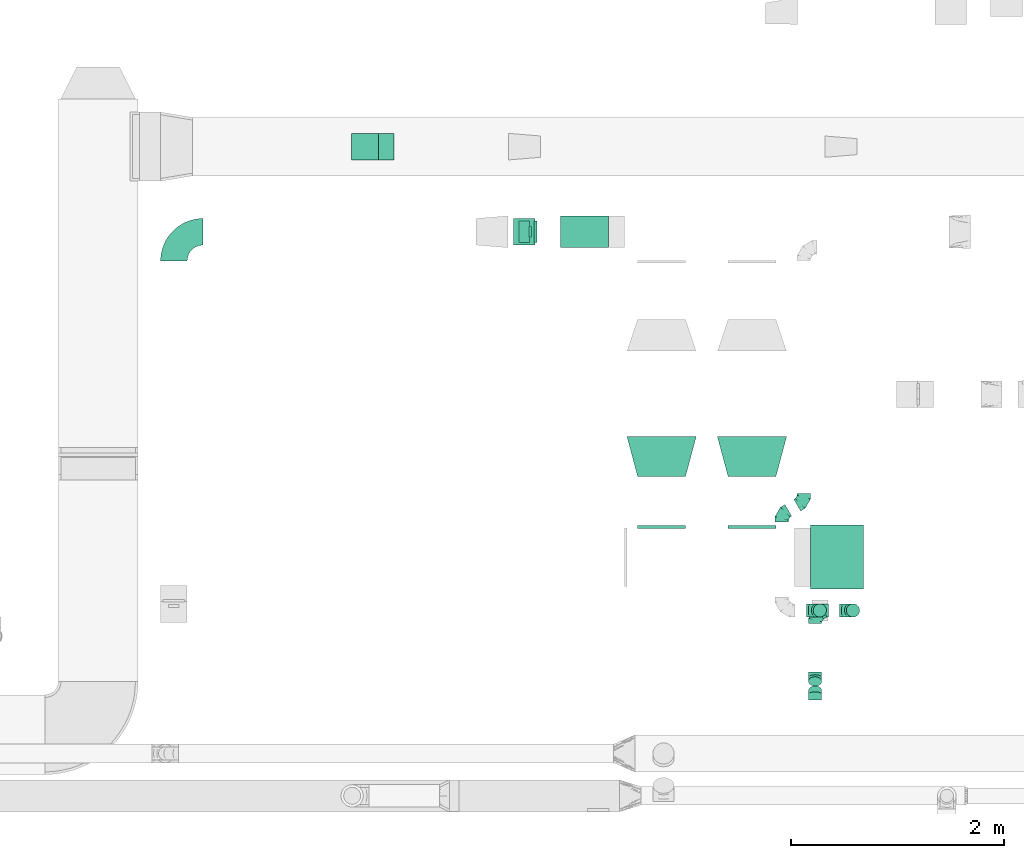
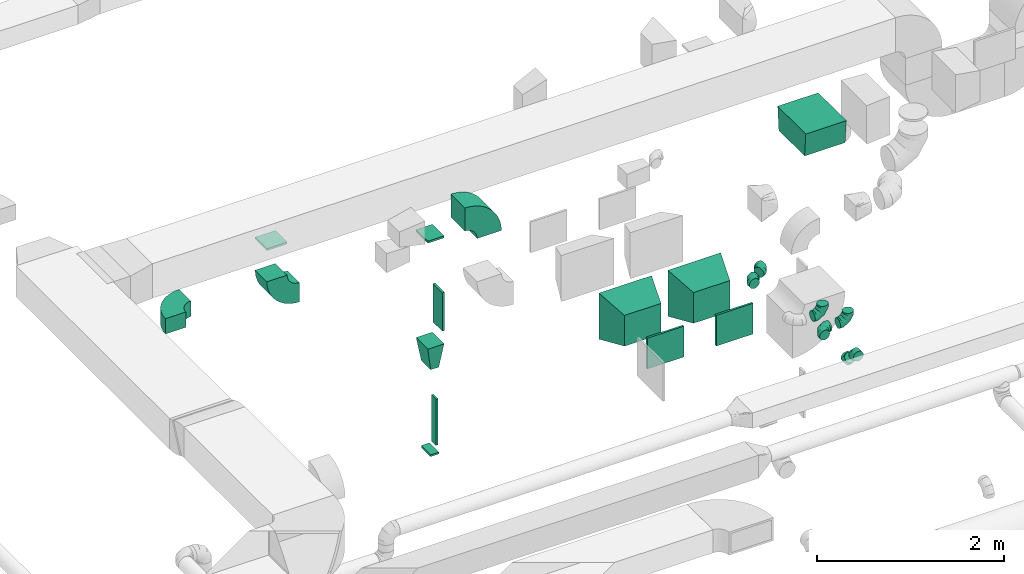
# One storey, part 57 of 97: 21 flow fittings.
"""IFC2X3 building model written with IfcOpenShell, lengths in millimetres."""

from ifc_helpers import new_model, entity, si_unit, converted_unit, derived_unit, direction, frame, frame_2d, origin, origin_2d_with_axis, place, context, subcontext, project, spatial, polyline, circle_curve, parameter, trimmed, segment, composite_curve, rectangle, outline, extrude, faceted_brep, source, transform, mapped, material, type_object, type_shapes, element, save


model = new_model("IFC2X3")

# Units and contexts
model_context = context("Model", 3, precision=0.01, world=origin(), true_north=direction((6.12303176911189e-17, 1.0)))
body_context = subcontext(model_context, "Body", "Model", "MODEL_VIEW")
ifc_project = project(units=[si_unit("LENGTHUNIT", "METRE", prefix="MILLI"), si_unit("AREAUNIT", "SQUARE_METRE"), si_unit("VOLUMEUNIT", "CUBIC_METRE"), converted_unit("PLANEANGLEUNIT", "DEGREE", entity("IfcRatioMeasure", 0.0174532925199433), si_unit("PLANEANGLEUNIT", "RADIAN"), dimensions=[0, 0, 0, 0, 0, 0, 0]), si_unit("MASSUNIT", "GRAM", prefix="KILO"), derived_unit("MASSDENSITYUNIT", [(si_unit("MASSUNIT", "GRAM", prefix="KILO"), 1), (si_unit("LENGTHUNIT", "METRE"), -3)]), derived_unit("MOMENTOFINERTIAUNIT", [(si_unit("LENGTHUNIT", "METRE"), 4)]), si_unit("TIMEUNIT", "SECOND"), si_unit("FREQUENCYUNIT", "HERTZ"), si_unit("THERMODYNAMICTEMPERATUREUNIT", "DEGREE_CELSIUS"), derived_unit("THERMALTRANSMITTANCEUNIT", [(si_unit("MASSUNIT", "GRAM", prefix="KILO"), 1), (si_unit("THERMODYNAMICTEMPERATUREUNIT", "KELVIN"), -1), (si_unit("TIMEUNIT", "SECOND"), -3)]), derived_unit("VOLUMETRICFLOWRATEUNIT", [(si_unit("LENGTHUNIT", "METRE"), 3), (si_unit("TIMEUNIT", "SECOND"), -1)]), derived_unit("MASSFLOWRATEUNIT", [(si_unit("MASSUNIT", "GRAM", prefix="KILO"), 1), (si_unit("TIMEUNIT", "SECOND"), -1)]), derived_unit("ROTATIONALFREQUENCYUNIT", [(si_unit("TIMEUNIT", "SECOND"), -1)]), si_unit("ELECTRICCURRENTUNIT", "AMPERE"), si_unit("ELECTRICVOLTAGEUNIT", "VOLT"), si_unit("POWERUNIT", "WATT"), si_unit("FORCEUNIT", "NEWTON", prefix="KILO"), si_unit("ILLUMINANCEUNIT", "LUX"), si_unit("LUMINOUSFLUXUNIT", "LUMEN"), si_unit("LUMINOUSINTENSITYUNIT", "CANDELA"), derived_unit("USERDEFINED", [(si_unit("MASSUNIT", "GRAM", prefix="KILO"), -1), (si_unit("LENGTHUNIT", "METRE"), -2), (si_unit("TIMEUNIT", "SECOND"), 3), (si_unit("LUMINOUSFLUXUNIT", "LUMEN"), 1)]), derived_unit("LINEARVELOCITYUNIT", [(si_unit("LENGTHUNIT", "METRE"), 1), (si_unit("TIMEUNIT", "SECOND"), -1)]), si_unit("PRESSUREUNIT", "PASCAL"), derived_unit("USERDEFINED", [(si_unit("LENGTHUNIT", "METRE"), -2), (si_unit("MASSUNIT", "GRAM", prefix="KILO"), 1), (si_unit("TIMEUNIT", "SECOND"), -2)]), derived_unit("LINEARFORCEUNIT", [(si_unit("MASSUNIT", "GRAM", prefix="KILO"), 1), (si_unit("LENGTHUNIT", "METRE"), 1), (si_unit("TIMEUNIT", "SECOND"), -2), (si_unit("LENGTHUNIT", "METRE"), -1)]), derived_unit("PLANARFORCEUNIT", [(si_unit("MASSUNIT", "GRAM", prefix="KILO"), 1), (si_unit("LENGTHUNIT", "METRE"), 1), (si_unit("TIMEUNIT", "SECOND"), -2), (si_unit("LENGTHUNIT", "METRE"), -2)])], contexts=[model_context])

# Site, building, storey
site_placement = place(None, origin())
site = spatial("IfcSite", under=ifc_project, at=site_placement, CompositionType="ELEMENT")
building_placement = place(site_placement, origin())
building = spatial("IfcBuilding", under=site, at=building_placement, CompositionType="ELEMENT")
storey_placement = place(building_placement, frame((0.0, 0.0, -4900.0)))
storey = spatial("IfcBuildingStorey", under=building, at=storey_placement, CompositionType="ELEMENT", Elevation=-4900.0)

# Flow fittings
ifc_material = material()
duct_fitting_type_1 = type_object("IfcDuctFittingType", PredefinedType="NOTDEFINED", material=ifc_material)
shared_shape_1 = source(origin(), body_context, "Body", "SweptSolid", [
    extrude(rectangle(XDim=250.0, YDim=26.0960000000487, at=origin_2d_with_axis()), frame((6.95, 0.0, -125.0), z_axis=(0.0, 0.0, 1.0), x_axis=(0.0, -1.0, 0.0)), (0.0, 0.0, 1.0), 250.0),
])
type_shapes(duct_fitting_type_1, [shared_shape_1])
flow_fitting_1_placement = place(storey_placement, frame((40818.26, 15349.1, 4000.0), z_axis=(1.0, 0.0, 0.0), x_axis=(0.0, 0.0, -1.0)))
element("IfcFlowFitting", 1, at=flow_fitting_1_placement, inside=storey, type_object=duct_fitting_type_1, material=ifc_material, context=body_context, shape_type="MappedRepresentation", body=[
    mapped(shared_shape_1, transform((0.0, 0.0, 0.0), scale=1.0)),
])
duct_fitting_type_2 = type_object("IfcDuctFittingType", PredefinedType="NOTDEFINED", material=ifc_material)
shared_shape_2 = source(origin(), body_context, "Body", "SweptSolid", [
    extrude(rectangle(XDim=26.0960000000008, YDim=500.0, at=origin_2d_with_axis()), frame((6.95, 0.0, -100.0)), (0.0, 0.0, 1.0), 200.0),
])
type_shapes(duct_fitting_type_2, [shared_shape_2])
flow_fitting_2_placement = place(storey_placement, frame((42414.6, 14548.39, 3050.0), z_axis=(0.0, -1.0, 0.0), x_axis=(1.0, 0.0, 0.0)))
element("IfcFlowFitting", 2, at=flow_fitting_2_placement, inside=storey, type_object=duct_fitting_type_2, material=ifc_material, context=body_context, shape_type="MappedRepresentation", body=[
    mapped(shared_shape_2, transform((0.0, 0.0, 0.0), scale=1.0)),
])
duct_fitting_type_3 = type_object("IfcDuctFittingType", PredefinedType="NOTDEFINED", material=ifc_material)
shared_shape_3 = source(origin(), body_context, "Body", "SweptSolid", [
    extrude(rectangle(XDim=26.0960000000009, YDim=600.0, at=origin_2d_with_axis()), frame((6.95, 0.0, -50.0)), (0.0, 0.0, 1.0), 100.0),
])
type_shapes(duct_fitting_type_3, [shared_shape_3])
flow_fitting_3_placement = place(storey_placement, frame((42364.6, 14548.39, 1600.0), z_axis=(0.0, -1.0, 0.0), x_axis=(1.0, 0.0, 0.0)))
element("IfcFlowFitting", 3, at=flow_fitting_3_placement, inside=storey, type_object=duct_fitting_type_3, material=ifc_material, context=body_context, shape_type="MappedRepresentation", body=[
    mapped(shared_shape_3, transform((0.0, 0.0, 0.0), scale=1.0)),
])
duct_fitting_type_4 = type_object("IfcDuctFittingType", PredefinedType="NOTDEFINED", material=ifc_material)
shared_shape_4 = source(origin(), body_context, "Body", "SweptSolid", [
    extrude(rectangle(XDim=26.0960000000029, YDim=450.0, at=origin_2d_with_axis()), frame((6.95, 0.0, -200.0)), (0.0, 0.0, 1.0), 400.0),
])
type_shapes(duct_fitting_type_4, [shared_shape_4])
for number, where, z_axis, x_axis in (
    (4, (43607.27, 11764.6, 3800.0), (0.0, 0.0, -1.0), (0.0, 1.0, 0.0)),
    (5, (44457.27, 11764.6, 3800.0), (0.0, 0.0, -1.0), (0.0, 1.0, 0.0)),
):
    element("IfcFlowFitting", number, at=place(storey_placement, frame(where, z_axis=z_axis, x_axis=x_axis)), inside=storey, type_object=duct_fitting_type_4, material=ifc_material, context=body_context, shape_type="MappedRepresentation", body=[
        mapped(shared_shape_4, transform((0.0, 0.0, 0.0), scale=1.0)),
    ])
duct_fitting_type_5 = type_object("IfcDuctFittingType", PredefinedType="NOTDEFINED", material=ifc_material)
shared_shape_5 = source(origin(), body_context, "Body", "SweptSolid", [
    extrude(rectangle(XDim=250.0, YDim=26.0960000000122, at=origin_2d_with_axis()), frame((6.95, 0.0, -100.0), z_axis=(0.0, 0.0, 1.0), x_axis=(0.0, -1.0, 0.0)), (0.0, 0.0, 1.0), 200.0),
])
type_shapes(duct_fitting_type_5, [shared_shape_5])
flow_fitting_4_placement = place(storey_placement, frame((42314.6, 14548.39, 4050.0), z_axis=(1.0, 0.0, 0.0), x_axis=(0.0, 0.0, -1.0)))
element("IfcFlowFitting", 6, at=flow_fitting_4_placement, inside=storey, type_object=duct_fitting_type_5, material=ifc_material, context=body_context, shape_type="MappedRepresentation", body=[
    mapped(shared_shape_5, transform((0.0, 0.0, 0.0), scale=1.0)),
])
duct_fitting_type_6 = type_object("IfcDuctFittingType", PredefinedType="NOTDEFINED", material=ifc_material)
shared_shape_6 = source(origin(), body_context, "Body", "SweptSolid", [
    extrude(rectangle(XDim=24.9999999999999, YDim=100.0, at=origin_2d_with_axis()), frame((12.5, 0.0, -100.0)), (0.0, 0.0, 1.0), 200.0),
])
type_shapes(duct_fitting_type_6, [shared_shape_6])
flow_fitting_5_placement = place(storey_placement, frame((42314.6, 14548.39, 1242.0), z_axis=(0.0, 1.0, 0.0), x_axis=(0.0, 0.0, -1.0)))
element("IfcFlowFitting", 7, at=flow_fitting_5_placement, inside=storey, type_object=duct_fitting_type_6, material=ifc_material, context=body_context, shape_type="MappedRepresentation", body=[
    mapped(shared_shape_6, transform((0.0, 0.0, 0.0), scale=1.0)),
])
duct_fitting_type_7 = type_object("IfcDuctFittingType", PredefinedType="NOTDEFINED", material=ifc_material)
shared_shape_7 = source(origin(), body_context, "Body", "SweptSolid", [
    extrude(outline(polyline([(-126.64, -286.51), (174.4, -286.51), (124.57, 311.42), (-172.32, 261.59), (-126.64, -286.51)])), frame((150.0, 0.0, -250.0), z_axis=(0.0, 0.0, 1.0), x_axis=(0.996545758244879, -0.0830454798537418, 0.0)), (0.0, 0.0, 1.0), 500.0),
])
type_shapes(duct_fitting_type_7, [shared_shape_7])
flow_fitting_6_placement = place(storey_placement, frame((45254.94, 11489.6, 6136.11), z_axis=(1.0, 0.0, 0.0), x_axis=(0.0, 0.0, 1.0)))
element("IfcFlowFitting", 8, at=flow_fitting_6_placement, inside=storey, type_object=duct_fitting_type_7, material=ifc_material, context=body_context, shape_type="MappedRepresentation", body=[
    mapped(shared_shape_7, transform((0.0, 0.0, 0.0), scale=1.0)),
])
duct_fitting_type_8 = type_object("IfcDuctFittingType", PredefinedType="NOTDEFINED", material=ifc_material)
shared_shape_8 = source(origin(), body_context, "Body", "Brep", [
    faceted_brep([(-125.0, 0.0, -62.5), (-125.0, -16.18, -60.37), (-125.0, -31.25, -54.13), (-125.0, -44.19, -44.19), (-125.0, -54.13, -31.25), (-125.0, -60.37, -16.18), (-125.0, -62.5, 0.0), (-125.0, -60.37, 16.18), (-125.0, -54.13, 31.25), (-125.0, -44.19, 44.19), (-125.0, -31.25, 54.13), (-125.0, -16.18, 60.37), (-125.0, 0.0, 62.5), (-125.0, 16.18, 60.37), (-125.0, 31.25, 54.13), (-125.0, 44.19, 44.19), (-125.0, 54.13, 31.25), (-125.0, 60.37, 16.18), (-125.0, 62.5, 0.0), (-125.0, 60.37, -16.18), (-125.0, 54.13, -31.25), (-125.0, 44.19, -44.19), (-125.0, 31.25, -54.13), (-125.0, 16.18, -60.37), (-95.84, 16.18, 60.37), (-99.88, 31.25, 54.13), (-91.51, 0.0, 62.5), (-103.35, 44.19, 44.19), (-107.68, 60.37, 16.18), (-108.25, 62.5, 0.0), (-106.01, 54.13, 31.25), (-106.01, 54.13, -31.25), (-103.35, 44.19, -44.19), (-107.68, 60.37, -16.18), (-95.84, 16.18, -60.37), (-91.51, 0.0, -62.5), (-99.88, 31.25, -54.13), (-87.17, -16.18, -60.37), (-83.13, -31.25, -54.13), (-79.66, -44.19, -44.19), (-77.0, -54.13, -31.25), (-75.33, -60.37, -16.18), (-74.76, -62.5, 0.0), (-75.33, -60.37, 16.18), (-77.0, -54.13, 31.25), (-79.66, -44.19, 44.19), (-83.13, -31.25, 54.13), (-87.17, -16.18, 60.37), (-45.34, 45.34, 60.37), (-56.37, 56.37, 54.13), (-33.49, 33.49, 62.5), (-65.85, 65.85, 44.19), (-73.12, 73.12, 31.25), (-77.69, 77.69, 16.18), (-79.25, 79.25, 0.0), (-77.69, 77.69, -16.18), (-73.12, 73.12, -31.25), (-65.85, 65.85, -44.19), (-45.34, 45.34, -60.37), (-33.49, 33.49, -62.5), (-56.37, 56.37, -54.13), (-21.65, 21.65, -60.37), (-10.62, 10.62, -54.13), (-1.14, 1.14, -44.19), (6.13, -6.13, -31.25), (10.7, -10.7, -16.18), (12.26, -12.26, 0.0), (10.7, -10.7, 16.18), (6.13, -6.13, 31.25), (-1.14, 1.14, 44.19), (-10.62, 10.62, 54.13), (-21.65, 21.65, 60.37), (-16.18, 95.84, 60.37), (-31.25, 99.88, 54.13), (0.0, 91.51, 62.5), (-44.19, 103.35, 44.19), (-54.13, 106.01, 31.25), (-60.37, 107.68, 16.18), (-62.5, 108.25, 0.0), (-60.37, 107.68, -16.18), (-54.13, 106.01, -31.25), (-44.19, 103.35, -44.19), (-16.18, 95.84, -60.37), (0.0, 91.51, -62.5), (-31.25, 99.88, -54.13), (16.18, 87.17, -60.37), (31.25, 83.13, -54.13), (44.19, 79.66, -44.19), (54.13, 77.0, -31.25), (60.37, 75.33, -16.18), (62.5, 74.76, 0.0), (60.37, 75.33, 16.18), (54.13, 77.0, 31.25), (44.19, 79.66, 44.19), (31.25, 83.13, 54.13), (16.18, 87.17, 60.37), (-16.18, 125.0, -60.37), (-31.25, 125.0, -54.13), (-44.19, 125.0, -44.19), (-54.13, 125.0, -31.25), (-60.37, 125.0, -16.18), (-62.5, 125.0, 0.0), (-60.37, 125.0, 16.18), (-54.13, 125.0, 31.25), (-44.19, 125.0, 44.19), (-31.25, 125.0, 54.13), (-16.18, 125.0, 60.37), (0.0, 125.0, 62.5), (16.18, 125.0, 60.37), (31.25, 125.0, 54.13), (44.19, 125.0, 44.19), (54.13, 125.0, 31.25), (60.37, 125.0, 16.18), (62.5, 125.0, 0.0), (60.37, 125.0, -16.18), (54.13, 125.0, -31.25), (44.19, 125.0, -44.19), (31.25, 125.0, -54.13), (16.18, 125.0, -60.37), (0.0, 125.0, -62.5)], [[[0, 1, 2, 3, 4, 5, 6, 7, 8, 9, 10, 11, 12, 13, 14, 15, 16, 17, 18, 19, 20, 21, 22, 23]], [[24, 25, 14, 13]], [[26, 24, 13, 12]], [[14, 25, 27, 15]], [[28, 29, 18, 17]], [[30, 28, 17, 16]], [[15, 27, 30, 16]], [[20, 31, 32, 21]], [[33, 31, 20, 19]], [[18, 29, 33, 19]], [[34, 35, 0, 23]], [[36, 34, 23, 22]], [[21, 32, 36, 22]], [[1, 0, 35, 37]], [[2, 1, 37, 38]], [[38, 39, 3, 2]], [[5, 4, 40, 41]], [[6, 5, 41, 42]], [[39, 40, 4, 3]], [[6, 42, 43, 7]], [[7, 43, 44, 8]], [[45, 9, 8, 44]], [[9, 45, 46, 10]], [[10, 46, 47, 11]], [[26, 12, 11, 47]], [[48, 49, 25, 24]], [[50, 48, 24, 26]], [[27, 25, 49, 51]], [[52, 53, 28, 30]], [[51, 52, 30, 27]], [[29, 28, 53, 54]], [[55, 56, 31, 33]], [[54, 55, 33, 29]], [[57, 32, 31, 56]], [[58, 59, 35, 34]], [[60, 58, 34, 36]], [[57, 60, 36, 32]], [[37, 35, 59, 61]], [[38, 37, 61, 62]], [[39, 38, 62, 63]], [[41, 40, 64, 65]], [[42, 41, 65, 66]], [[63, 64, 40, 39]], [[43, 42, 66, 67]], [[44, 43, 67, 68]], [[68, 69, 45, 44]], [[46, 45, 69, 70]], [[47, 46, 70, 71]], [[26, 47, 71, 50]], [[72, 73, 49, 48]], [[74, 72, 48, 50]], [[51, 49, 73, 75]], [[76, 77, 53, 52]], [[75, 76, 52, 51]], [[54, 53, 77, 78]], [[79, 80, 56, 55]], [[78, 79, 55, 54]], [[81, 57, 56, 80]], [[82, 83, 59, 58]], [[84, 82, 58, 60]], [[81, 84, 60, 57]], [[61, 59, 83, 85]], [[62, 61, 85, 86]], [[63, 62, 86, 87]], [[65, 64, 88, 89]], [[66, 65, 89, 90]], [[87, 88, 64, 63]], [[67, 66, 90, 91]], [[68, 67, 91, 92]], [[92, 93, 69, 68]], [[70, 69, 93, 94]], [[71, 70, 94, 95]], [[50, 71, 95, 74]], [[96, 97, 98, 99, 100, 101, 102, 103, 104, 105, 106, 107, 108, 109, 110, 111, 112, 113, 114, 115, 116, 117, 118, 119]], [[72, 74, 107, 106]], [[73, 72, 106, 105]], [[75, 73, 105, 104]], [[77, 76, 103, 102]], [[78, 77, 102, 101]], [[75, 104, 103, 76]], [[78, 101, 100, 79]], [[79, 100, 99, 80]], [[80, 99, 98, 81]], [[96, 119, 83, 82]], [[97, 96, 82, 84]], [[84, 81, 98, 97]], [[83, 119, 118, 85]], [[85, 118, 117, 86]], [[116, 87, 86, 117]], [[88, 115, 114, 89]], [[89, 114, 113, 90]], [[115, 88, 87, 116]], [[91, 90, 113, 112]], [[92, 91, 112, 111]], [[111, 110, 93, 92]], [[95, 94, 109, 108]], [[74, 95, 108, 107]], [[110, 109, 94, 93]]]),
])
type_shapes(duct_fitting_type_8, [shared_shape_8])
for number, where, z_axis, x_axis in (
    (9, (45095.05, 10988.58, 4200.0), (0.0, -1.0, 0.0), (1.0, 0.0, 0.0)),
    (10, (45406.65, 10988.57, 4000.0), (0.0, -1.0, 0.0), (1.0, 0.0, 0.0)),
    (11, (45050.47, 10988.57, 4000.0), (0.0, 0.0, 1.0), (-1.0, 0.0, 0.0)),
):
    element("IfcFlowFitting", number, at=place(storey_placement, frame(where, z_axis=z_axis, x_axis=x_axis)), inside=storey, type_object=duct_fitting_type_8, material=ifc_material, context=body_context, shape_type="MappedRepresentation", body=[
        mapped(shared_shape_8, transform((0.0, 0.0, 0.0), scale=1.0)),
    ])
duct_fitting_type_9 = type_object("IfcDuctFittingType", PredefinedType="NOTDEFINED", material=ifc_material)
shared_shape_9 = source(origin(), body_context, "Body", "Brep", [
    faceted_brep([(-51.78, 0.0, -62.5), (-51.78, -16.18, -60.37), (-51.78, -31.25, -54.13), (-51.78, -44.19, -44.19), (-51.78, -54.13, -31.25), (-51.78, -60.37, -16.18), (-51.78, -62.5, 0.0), (-51.78, -60.37, 16.18), (-51.78, -54.13, 31.25), (-51.78, -44.19, 44.19), (-51.78, -31.25, 54.13), (-51.78, -16.18, 60.37), (-51.78, 0.0, 62.5), (-51.78, 16.18, 60.37), (-51.78, 31.25, 54.13), (-51.78, 44.19, 44.19), (-51.78, 54.13, 31.25), (-51.78, 60.37, 16.18), (-51.78, 62.5, 0.0), (-51.78, 60.37, -16.18), (-51.78, 54.13, -31.25), (-51.78, 44.19, -44.19), (-51.78, 31.25, -54.13), (-51.78, 16.18, -60.37), (-6.7, 16.18, 60.37), (-12.94, 31.25, 54.13), (0.0, 0.0, 62.5), (-18.31, 44.19, 44.19), (-22.42, 54.13, 31.25), (-25.01, 60.37, 16.18), (-25.89, 62.5, 0.0), (-25.01, 60.37, -16.18), (-22.42, 54.13, -31.25), (-18.31, 44.19, -44.19), (-6.7, 16.18, -60.37), (0.0, 0.0, -62.5), (-12.94, 31.25, -54.13), (6.7, -16.18, -60.37), (12.94, -31.25, -54.13), (18.31, -44.19, -44.19), (22.42, -54.13, -31.25), (25.01, -60.37, -16.18), (25.89, -62.5, 0.0), (25.01, -60.37, 16.18), (22.42, -54.13, 31.25), (18.31, -44.19, 44.19), (12.94, -31.25, 54.13), (6.7, -16.18, 60.37), (25.17, 48.05, 60.37), (14.51, 58.71, 54.13), (36.61, 36.61, 62.5), (5.36, 67.86, 44.19), (-1.66, 74.88, 31.25), (-6.08, 79.3, 16.18), (-7.58, 80.81, 0.0), (-6.08, 79.3, -16.18), (-1.66, 74.88, -31.25), (5.36, 67.86, -44.19), (14.51, 58.71, -54.13), (25.17, 48.05, -60.37), (36.61, 36.61, -62.5), (48.05, 25.17, -60.37), (58.71, 14.51, -54.13), (67.86, 5.36, -44.19), (74.88, -1.66, -31.25), (79.3, -6.08, -16.18), (80.81, -7.58, 0.0), (79.3, -6.08, 16.18), (74.88, -1.66, 31.25), (67.86, 5.36, 44.19), (58.71, 14.51, 54.13), (48.05, 25.17, 60.37)], [[[0, 1, 2, 3, 4, 5, 6, 7, 8, 9, 10, 11, 12, 13, 14, 15, 16, 17, 18, 19, 20, 21, 22, 23]], [[24, 25, 14, 13]], [[26, 24, 13, 12]], [[27, 15, 14, 25]], [[28, 29, 17, 16]], [[28, 16, 15, 27]], [[30, 18, 17, 29]], [[31, 32, 20, 19]], [[30, 31, 19, 18]], [[21, 20, 32, 33]], [[34, 35, 0, 23]], [[36, 34, 23, 22]], [[33, 36, 22, 21]], [[1, 0, 35, 37]], [[2, 1, 37, 38]], [[38, 39, 3, 2]], [[5, 4, 40, 41]], [[6, 5, 41, 42]], [[39, 40, 4, 3]], [[6, 42, 43, 7]], [[7, 43, 44, 8]], [[8, 44, 45, 9]], [[9, 45, 46, 10]], [[10, 46, 47, 11]], [[26, 12, 11, 47]], [[48, 49, 25, 24]], [[50, 48, 24, 26]], [[27, 25, 49, 51]], [[29, 28, 52, 53]], [[30, 29, 53, 54]], [[51, 52, 28, 27]], [[30, 54, 55, 31]], [[31, 55, 56, 32]], [[57, 33, 32, 56]], [[36, 58, 59, 34]], [[34, 59, 60, 35]], [[58, 36, 33, 57]], [[35, 60, 61, 37]], [[37, 61, 62, 38]], [[63, 39, 38, 62]], [[40, 64, 65, 41]], [[41, 65, 66, 42]], [[64, 40, 39, 63]], [[43, 42, 66, 67]], [[44, 43, 67, 68]], [[68, 69, 45, 44]], [[47, 46, 70, 71]], [[26, 47, 71, 50]], [[69, 70, 46, 45]], [[59, 58, 57, 56, 55, 54, 53, 52, 51, 49, 48, 50, 71, 70, 69, 68, 67, 66, 65, 64, 63, 62, 61, 60]]]),
])
type_shapes(duct_fitting_type_9, [shared_shape_9])
for number, where, z_axis, x_axis in (
    (12, (45050.47, 10357.85, 4000.0), (-1.0, 0.0, 0.0), (0.0, -1.0, 0.0)),
    (13, (45050.47, 10197.85, 4160.0), (1.0, 0.0, 0.0), (0.0, -0.707106781186442, 0.707106781186653)),
):
    element("IfcFlowFitting", number, at=place(storey_placement, frame(where, z_axis=z_axis, x_axis=x_axis)), inside=storey, type_object=duct_fitting_type_9, material=ifc_material, context=body_context, shape_type="MappedRepresentation", body=[
        mapped(shared_shape_9, transform((0.0, 0.0, 0.0), scale=1.0)),
    ])
duct_fitting_type_10 = type_object("IfcDuctFittingType", PredefinedType="NOTDEFINED", material=ifc_material)
shared_shape_10 = source(origin(), body_context, "Body", "Brep", [
    faceted_brep([(-72.17, 0.0, -62.5), (-72.17, -16.18, -60.37), (-72.17, -31.25, -54.13), (-72.17, -44.19, -44.19), (-72.17, -54.13, -31.25), (-72.17, -60.37, -16.18), (-72.17, -62.5, 0.0), (-72.17, -60.37, 16.18), (-72.17, -54.13, 31.25), (-72.17, -44.19, 44.19), (-72.17, -31.25, 54.13), (-72.17, -16.18, 60.37), (-72.17, 0.0, 62.5), (-72.17, 16.18, 60.37), (-72.17, 31.25, 54.13), (-72.17, 44.19, 44.19), (-72.17, 54.13, 31.25), (-72.17, 60.37, 16.18), (-72.17, 62.5, 0.0), (-72.17, 60.37, -16.18), (-72.17, 54.13, -31.25), (-72.17, 44.19, -44.19), (-72.17, 31.25, -54.13), (-72.17, 16.18, -60.37), (-43.01, 16.18, 60.37), (-47.05, 31.25, 54.13), (-38.68, 0.0, 62.5), (-50.52, 44.19, 44.19), (-54.85, 60.37, 16.18), (-55.42, 62.5, 0.0), (-53.18, 54.13, 31.25), (-53.18, 54.13, -31.25), (-50.52, 44.19, -44.19), (-54.85, 60.37, -16.18), (-43.01, 16.18, -60.37), (-38.68, 0.0, -62.5), (-47.05, 31.25, -54.13), (-34.34, -16.18, -60.37), (-30.3, -31.25, -54.13), (-26.83, -44.19, -44.19), (-24.17, -54.13, -31.25), (-22.5, -60.37, -16.18), (-21.93, -62.5, 0.0), (-22.5, -60.37, 16.18), (-24.17, -54.13, 31.25), (-26.83, -44.19, 44.19), (-30.3, -31.25, 54.13), (-34.34, -16.18, 60.37), (7.5, 45.34, 60.37), (-3.54, 56.37, 54.13), (19.34, 33.49, 62.5), (-13.01, 65.85, 44.19), (-20.29, 73.12, 31.25), (-24.86, 77.69, 16.18), (-26.42, 79.25, 0.0), (-24.86, 77.69, -16.18), (-20.29, 73.12, -31.25), (-13.01, 65.85, -44.19), (7.5, 45.34, -60.37), (19.34, 33.49, -62.5), (-3.54, 56.37, -54.13), (31.18, 21.65, -60.37), (42.21, 10.62, -54.13), (51.69, 1.14, -44.19), (58.96, -6.13, -31.25), (63.53, -10.7, -16.18), (65.09, -12.26, 0.0), (63.53, -10.7, 16.18), (58.96, -6.13, 31.25), (51.69, 1.14, 44.19), (42.21, 10.62, 54.13), (31.18, 21.65, 60.37), (36.08, 62.5, 62.5), (22.08, 70.59, 60.37), (9.02, 78.12, 54.13), (-2.19, 84.6, 44.19), (-10.79, 89.56, 31.25), (-16.2, 92.69, 16.18), (-18.04, 93.75, 0.0), (-16.2, 92.69, -16.18), (-10.79, 89.56, -31.25), (-2.19, 84.6, -44.19), (22.08, 70.59, -60.37), (36.08, 62.5, -62.5), (9.02, 78.12, -54.13), (50.09, 54.41, -60.37), (63.15, 46.87, -54.13), (74.36, 40.4, -44.19), (82.96, 35.44, -31.25), (88.37, 32.31, -16.18), (90.21, 31.25, 0.0), (88.37, 32.31, 16.18), (82.96, 35.44, 31.25), (74.36, 40.4, 44.19), (63.15, 46.87, 54.13), (50.09, 54.41, 60.37)], [[[0, 1, 2, 3, 4, 5, 6, 7, 8, 9, 10, 11, 12, 13, 14, 15, 16, 17, 18, 19, 20, 21, 22, 23]], [[24, 25, 14, 13]], [[26, 24, 13, 12]], [[14, 25, 27, 15]], [[28, 29, 18, 17]], [[30, 28, 17, 16]], [[15, 27, 30, 16]], [[20, 31, 32, 21]], [[33, 31, 20, 19]], [[18, 29, 33, 19]], [[34, 35, 0, 23]], [[36, 34, 23, 22]], [[21, 32, 36, 22]], [[1, 0, 35, 37]], [[2, 1, 37, 38]], [[38, 39, 3, 2]], [[5, 4, 40, 41]], [[6, 5, 41, 42]], [[39, 40, 4, 3]], [[6, 42, 43, 7]], [[7, 43, 44, 8]], [[45, 9, 8, 44]], [[9, 45, 46, 10]], [[10, 46, 47, 11]], [[26, 12, 11, 47]], [[48, 49, 25, 24]], [[50, 48, 24, 26]], [[27, 25, 49, 51]], [[52, 53, 28, 30]], [[51, 52, 30, 27]], [[29, 28, 53, 54]], [[55, 56, 31, 33]], [[54, 55, 33, 29]], [[57, 32, 31, 56]], [[58, 59, 35, 34]], [[60, 58, 34, 36]], [[57, 60, 36, 32]], [[37, 35, 59, 61]], [[38, 37, 61, 62]], [[39, 38, 62, 63]], [[41, 40, 64, 65]], [[42, 41, 65, 66]], [[63, 64, 40, 39]], [[43, 42, 66, 67]], [[44, 43, 67, 68]], [[68, 69, 45, 44]], [[46, 45, 69, 70]], [[47, 46, 70, 71]], [[26, 47, 71, 50]], [[48, 50, 72, 73]], [[49, 48, 73, 74]], [[51, 49, 74, 75]], [[53, 52, 76, 77]], [[54, 53, 77, 78]], [[51, 75, 76, 52]], [[54, 78, 79, 55]], [[55, 79, 80, 56]], [[56, 80, 81, 57]], [[82, 83, 59, 58]], [[84, 82, 58, 60]], [[60, 57, 81, 84]], [[59, 83, 85, 61]], [[61, 85, 86, 62]], [[87, 63, 62, 86]], [[64, 88, 89, 65]], [[65, 89, 90, 66]], [[88, 64, 63, 87]], [[67, 66, 90, 91]], [[68, 67, 91, 92]], [[92, 93, 69, 68]], [[71, 70, 94, 95]], [[50, 71, 95, 72]], [[93, 94, 70, 69]], [[82, 84, 81, 80, 79, 78, 77, 76, 75, 74, 73, 72, 95, 94, 93, 92, 91, 90, 89, 88, 87, 86, 85, 83]]]),
])
type_shapes(duct_fitting_type_10, [shared_shape_10])
for number, where, z_axis, x_axis in (
    (14, (44736.23, 11893.23, 4200.0), (0.0, 0.0, 1.0), (-0.866025403784436, -0.500000000000004, 0.0)),
    (15, (44945.15, 12013.84, 4200.0), (0.0, 0.0, 1.0), (0.86602540378444, 0.499999999999998, 0.0)),
):
    element("IfcFlowFitting", number, at=place(storey_placement, frame(where, z_axis=z_axis, x_axis=x_axis)), inside=storey, type_object=duct_fitting_type_10, material=ifc_material, context=body_context, shape_type="MappedRepresentation", body=[
        mapped(shared_shape_10, transform((0.0, 0.0, 0.0), scale=1.0)),
    ])
duct_fitting_type_11 = type_object("IfcDuctFittingType", PredefinedType="NOTDEFINED", material=ifc_material)
shared_shape_11 = source(origin(), body_context, "Body", "Brep", [
    faceted_brep([(373.3, -325.0, 300.0), (373.3, -325.0, -300.0), (373.3, 325.0, -300.0), (373.3, 325.0, 300.0), (0.0, -225.0, 200.0), (0.0, 225.0, 200.0), (0.0, 225.0, -200.0), (0.0, -225.0, -200.0)], [[[0, 1, 2, 3]], [[4, 5, 6, 7]], [[4, 7, 1, 0]], [[7, 6, 2, 1]], [[6, 5, 3, 2]], [[5, 4, 0, 3]]]),
])
type_shapes(duct_fitting_type_11, [shared_shape_11])
for number, where, z_axis, x_axis in (
    (16, (43607.27, 12248.32, 3800.0), (0.0, 0.0, 1.0), (0.0, 1.0, 0.0)),
    (17, (44457.27, 12248.32, 3800.0), (0.0, 0.0, 1.0), (0.0, 1.0, 0.0)),
):
    element("IfcFlowFitting", number, at=place(storey_placement, frame(where, z_axis=z_axis, x_axis=x_axis)), inside=storey, type_object=duct_fitting_type_11, material=ifc_material, context=body_context, shape_type="MappedRepresentation", body=[
        mapped(shared_shape_11, transform((0.0, 0.0, 0.0), scale=1.0)),
    ])
duct_fitting_type_12 = type_object("IfcDuctFittingType", PredefinedType="NOTDEFINED", material=ifc_material)
shared_shape_12 = source(origin(), body_context, "Body", "Brep", [
    faceted_brep([(300.0, -100.0, 125.0), (300.0, -100.0, -125.0), (300.0, 100.0, -125.0), (300.0, 100.0, 125.0), (0.0, -50.0, 100.0), (0.0, 50.0, 100.0), (0.0, 50.0, -100.0), (0.0, -50.0, -100.0)], [[[0, 1, 2, 3]], [[4, 5, 6, 7]], [[4, 7, 1, 0]], [[7, 6, 2, 1]], [[6, 5, 3, 2]], [[5, 4, 0, 3]]]),
])
type_shapes(duct_fitting_type_12, [shared_shape_12])
flow_fitting_7_placement = place(storey_placement, frame((42314.6, 14548.39, 2350.0), z_axis=(0.0, 1.0, 0.0), x_axis=(0.0, 0.0, 1.0)))
element("IfcFlowFitting", 18, at=flow_fitting_7_placement, inside=storey, type_object=duct_fitting_type_12, material=ifc_material, context=body_context, shape_type="MappedRepresentation", body=[
    mapped(shared_shape_12, transform((0.0, 0.0, 0.0), scale=1.0)),
])
duct_fitting_type_13 = type_object("IfcDuctFittingType", PredefinedType="NOTDEFINED", material=ifc_material)
shared_shape_13 = source(origin(), body_context, "Body", "SweptSolid", [
    extrude(outline(composite_curve([segment(polyline([(-262.5, -137.5), (-12.5, -137.5)]), True, "CONTINUOUS"), segment(trimmed(circle_curve(frame_2d((137.5, -137.5), x_axis=(0.0, 1.0)), 150.0), [parameter(0.0)], [parameter(90.0000000000001)], True, "PARAMETER"), False, "CONTINUOUS"), segment(polyline([(137.5, 12.5), (137.5, 262.5)]), True, "CONTINUOUS"), segment(trimmed(circle_curve(frame_2d((137.5, -137.5), x_axis=(0.0, 1.0)), 400.0), [parameter(0.0)], [parameter(90.0000000000001)], True, "PARAMETER"), True, "CONTINUOUS")], self_intersect=False)), frame((-137.5, 137.5, -125.0), z_axis=(0.0, 0.0, 1.0), x_axis=(-1.0, 0.0, 0.0)), (0.0, 0.0, 1.0), 250.0),
])
type_shapes(duct_fitting_type_13, [shared_shape_13])
flow_fitting_8_placement = place(storey_placement, frame((40818.26, 15348.96, 3300.0), z_axis=(0.0, -1.0, 0.0), x_axis=(0.0, 0.0, -1.0)))
element("IfcFlowFitting", 19, at=flow_fitting_8_placement, inside=storey, type_object=duct_fitting_type_13, material=ifc_material, context=body_context, shape_type="MappedRepresentation", body=[
    mapped(shared_shape_13, transform((0.0, 0.0, 0.0), scale=1.0)),
])
duct_fitting_type_14 = type_object("IfcDuctFittingType", PredefinedType="NOTDEFINED", material=ifc_material)
shared_shape_14 = source(origin(), body_context, "Body", "SweptSolid", [
    extrude(outline(composite_curve([segment(polyline([(-300.0, -150.0), (0.0, -150.0)]), True, "CONTINUOUS"), segment(trimmed(circle_curve(frame_2d((150.0, -150.0), x_axis=(0.0, 1.0)), 150.0), [parameter(0.0)], [parameter(90.0)], True, "PARAMETER"), False, "CONTINUOUS"), segment(polyline([(150.0, 0.0), (150.0, 300.0)]), True, "CONTINUOUS"), segment(trimmed(circle_curve(frame_2d((150.0, -150.0), x_axis=(0.0, 1.0)), 450.0), [parameter(0.0)], [parameter(90.0000000000001)], True, "PARAMETER"), True, "CONTINUOUS")], self_intersect=False)), frame((-150.0, 150.0, -150.0), z_axis=(0.0, 0.0, 1.0), x_axis=(-1.0, 0.0, 0.0)), (0.0, 0.0, 1.0), 300.0),
])
type_shapes(duct_fitting_type_14, [shared_shape_14])
flow_fitting_9_placement = place(storey_placement, frame((42957.3, 14548.39, 4200.0), z_axis=(0.0, -1.0, 0.0), x_axis=(0.0, 0.0, 1.0)))
element("IfcFlowFitting", 20, at=flow_fitting_9_placement, inside=storey, type_object=duct_fitting_type_14, material=ifc_material, context=body_context, shape_type="MappedRepresentation", body=[
    mapped(shared_shape_14, transform((0.0, 0.0, 0.0), scale=1.0)),
])
duct_fitting_type_15 = type_object("IfcDuctFittingType", PredefinedType="NOTDEFINED", material=ifc_material)
shared_shape_15 = source(origin(), body_context, "Body", "SweptSolid", [
    extrude(outline(composite_curve([segment(polyline([(-262.5, -137.5), (-12.5, -137.5)]), True, "CONTINUOUS"), segment(trimmed(circle_curve(frame_2d((137.5, -137.5), x_axis=(0.0, 1.0)), 150.0), [parameter(0.0)], [parameter(90.0000000000001)], True, "PARAMETER"), False, "CONTINUOUS"), segment(polyline([(137.5, 12.5), (137.5, 262.5)]), True, "CONTINUOUS"), segment(trimmed(circle_curve(frame_2d((137.5, -137.5), x_axis=(0.0, 1.0)), 400.0), [parameter(0.0)], [parameter(90.0000000000001)], True, "PARAMETER"), True, "CONTINUOUS")], self_intersect=False)), frame((-137.5, 137.5, -100.0), z_axis=(0.0, 0.0, 1.0), x_axis=(-1.0, 0.0, 0.0)), (0.0, 0.0, 1.0), 200.0),
])
type_shapes(duct_fitting_type_15, [shared_shape_15])
flow_fitting_10_placement = place(storey_placement, frame((39021.44, 14548.39, 4200.0), z_axis=(0.0, 0.0, 1.0), x_axis=(-1.0, 0.0, 0.0)))
element("IfcFlowFitting", 21, at=flow_fitting_10_placement, inside=storey, type_object=duct_fitting_type_15, material=ifc_material, context=body_context, shape_type="MappedRepresentation", body=[
    mapped(shared_shape_15, transform((0.0, 0.0, 0.0), scale=1.0)),
])

save(model, "model.ifc")
